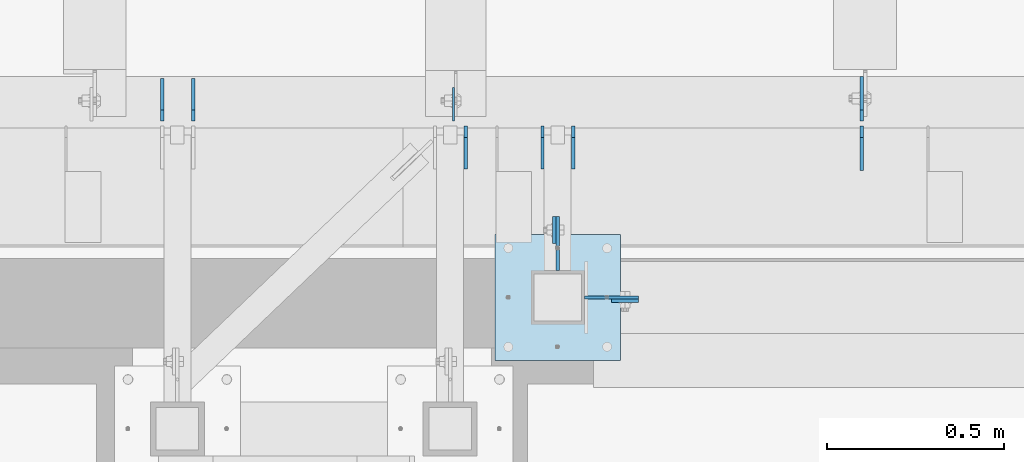
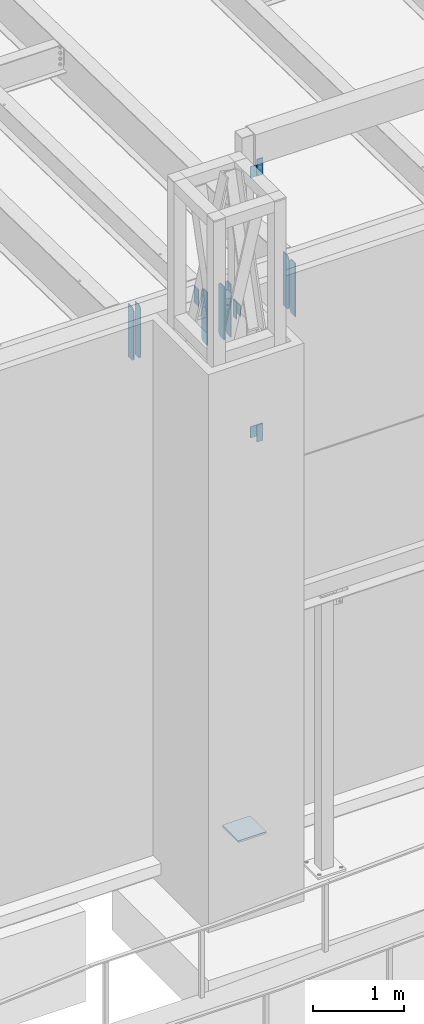
# One storey, part 1430 of 1763: 15 plates, 5 elements without a shape of their own.
"""IFC2X3 building model written with IfcOpenShell, lengths in millimetres."""

import ifcopenshell
import ifcopenshell.guid

model = None  # the IFC model being written
_history = None  # IfcOwnerHistory: only IFC2X3 demands one
_inside = {}  # id of a spatial element -> (the spatial element, [elements in it])
_under = {}  # id of a project, library or spatial element -> (it, [spatial elements below it])
_declared = {}  # id of a project -> (the project, [libraries it declares])
_typed = {}  # id of a type object -> (the type object, [elements of that type])
_made_of = {}  # id of a material, layer set ... -> (it, [elements and type objects made of it])


def new_model(schema):
    """Start an empty IFC model of exactly this schema.

    Asked for "IFC4X3", IfcOpenShell would pick the latest addendum, in which some entities
    have other attributes; the version numbers below select the first issue.
    IFC2X3 requires an IfcOwnerHistory on every rooted entity: one is made here for all.
    """
    global model, _history
    if schema == "IFC4X3":
        model = ifcopenshell.file(schema_version=(4, 3, 0, 0))
    else:
        model = ifcopenshell.file(schema=schema)
    _inside.clear()
    _under.clear()
    _declared.clear()
    _typed.clear()
    _made_of.clear()
    _history = None
    if model.schema == "IFC2X3":
        org = make("IfcOrganization", Name="unknown")
        user = make(
            "IfcPersonAndOrganization",
            ThePerson=make("IfcPerson", FamilyName="unknown"),
            TheOrganization=org,
        )
        app = make(
            "IfcApplication",
            ApplicationDeveloper=org,
            Version="unknown",
            ApplicationFullName="unknown",
            ApplicationIdentifier="unknown",
        )
        _history = make(
            "IfcOwnerHistory",
            OwningUser=user,
            OwningApplication=app,
            ChangeAction="ADDED",
            CreationDate=0,
        )
    return model


def make(cls, **values):
    """One entity of the class cls with the attributes given. An attribute that is None is left unset."""
    return model.create_entity(
        cls, **{name: value for name, value in values.items() if value is not None}
    )


def rooted(cls, **values):
    """An entity with a GlobalId (a new one), such as an element, a storey or a relation."""
    return make(cls, GlobalId=ifcopenshell.guid.new(), OwnerHistory=_history, **values)


def si_unit(unit_type, name, prefix=None):
    """IfcSIUnit, for example si_unit("LENGTHUNIT", "METRE", prefix="MILLI")."""
    return make("IfcSIUnit", UnitType=unit_type, Prefix=prefix, Name=name)


def assignment(units):
    """IfcUnitAssignment: the units of a project."""
    return None if units is None else make("IfcUnitAssignment", Units=units)


def point(xyz):
    """IfcCartesianPoint."""
    return None if xyz is None else make("IfcCartesianPoint", Coordinates=xyz)


def direction(xyz):
    """IfcDirection."""
    return None if xyz is None else make("IfcDirection", DirectionRatios=xyz)


def frame(location, z_axis=None, x_axis=None):
    """IfcAxis2Placement3D, a coordinate frame: its origin and axes. An axis left out is left unset."""
    return make(
        "IfcAxis2Placement3D",
        Location=point(location),
        Axis=direction(z_axis),
        RefDirection=direction(x_axis),
    )


def origin_with_axes():
    """The frame at (0, 0, 0) with the z axis (0, 0, 1) and the x axis (1, 0, 0) written out."""
    return frame((0.0, 0.0, 0.0), z_axis=(0.0, 0.0, 1.0), x_axis=(1.0, 0.0, 0.0))


def place(relative_to, where):
    """IfcLocalPlacement: puts the frame where relative to a parent placement (None: the world)."""
    return make(
        "IfcLocalPlacement", PlacementRelTo=relative_to, RelativePlacement=where
    )


def context(
    kind, dimensions, precision=None, world=None, true_north=None, identifier=None
):
    """IfcGeometricRepresentationContext, for example the 3D "Model" context."""
    return make(
        "IfcGeometricRepresentationContext",
        ContextIdentifier=identifier,
        ContextType=kind,
        CoordinateSpaceDimension=dimensions,
        Precision=precision,
        WorldCoordinateSystem=world,
        TrueNorth=true_north,
    )


def subcontext(parent, identifier, kind, view, scale=None):
    """IfcGeometricRepresentationSubContext, for example "Body" below "Model"."""
    return make(
        "IfcGeometricRepresentationSubContext",
        ContextIdentifier=identifier,
        ContextType=kind,
        ParentContext=parent,
        TargetScale=scale,
        TargetView=view,
    )


def project(units=None, contexts=None):
    """IfcProject with its units and contexts."""
    return rooted(
        "IfcProject",
        Name="project",
        RepresentationContexts=contexts,
        UnitsInContext=assignment(units),
    )


def spatial(cls, under=None, at=None, **own):
    """A site, building, storey or space (cls), placed at a placement, below another one or the project."""
    s = rooted(cls, ObjectPlacement=at, **own)
    if under is not None:
        _under.setdefault(under.id(), (under, []))[1].append(s)
    return s


def faces_of(points, faces, orient=None, outer=None):
    """IfcFace entities. A face is a list of loops; a loop is a list of indices into points, from 0.

    orient and outer hold one flag for each loop. By default every Orientation is true, the
    first loop of a face is its IfcFaceOuterBound and the others are IfcFaceBound.
    """
    made = []
    for i, loops in enumerate(faces):
        bounds = []
        for j, loop in enumerate(loops):
            is_outer = j == 0 if outer is None else outer[i][j]
            bounds.append(
                make(
                    "IfcFaceOuterBound" if is_outer else "IfcFaceBound",
                    Bound=make("IfcPolyLoop", Polygon=[points[k] for k in loop]),
                    Orientation=True if orient is None else orient[i][j],
                )
            )
        made.append(make("IfcFace", Bounds=bounds))
    return made


def faceted_brep(points, faces, orient=None, outer=None, voids=None):
    """IfcFacetedBrep: a solid bounded by flat faces; with voids (closed shells), ...WithVoids."""
    shared = [point(p) for p in points]
    hull = make("IfcClosedShell", CfsFaces=faces_of(shared, faces, orient, outer))
    if voids is None:
        return make("IfcFacetedBrep", Outer=hull)
    return make(
        "IfcFacetedBrepWithVoids",
        Outer=hull,
        Voids=[
            make(cls, CfsFaces=faces_of(shared, fs, o, b)) for cls, fs, o, b in voids
        ],
    )


def shape(context_of_items, identifier, shape_type, items):
    """IfcShapeRepresentation: the items that make up one representation, for example the "Body"."""
    return make(
        "IfcShapeRepresentation",
        ContextOfItems=context_of_items,
        RepresentationIdentifier=identifier,
        RepresentationType=shape_type,
        Items=items,
    )


def material(Name=None, Category=None):
    """IfcMaterial."""
    return make("IfcMaterial", Name=Name, Category=Category)


def made_of(thing, what):
    """Note that an element or type object is made of a material, layer set ...; save() writes the relation."""
    if what is not None:
        _made_of.setdefault(what.id(), (what, []))[1].append(thing)
    return thing


def type_object(cls, material=None, **own):
    """A type object (cls), such as IfcWallType, which elements share."""
    return made_of(rooted(cls, **own), material)


def element(
    cls,
    number,
    at=None,
    inside=None,
    cuts=None,
    type_object=None,
    material=None,
    context=None,
    identifier="Body",
    shape_type=None,
    held_by="IfcProductDefinitionShape",
    body=None,
    shapes=None,
    **own,
):
    """One element of the class cls, such as IfcWall. Its Tag is "e" and its number.

    at: its placement. inside: the storey or other place that contains it. cuts: it is an
    opening in that element (IfcRelVoidsElement). A single representation is given by context,
    identifier, shape_type and body (its items); several are given by shapes. held_by: the class
    of the entity that holds the representations. save() writes the other relations.
    """
    e = rooted(cls, Tag="e%d" % number, ObjectPlacement=at, **own)
    if body is not None:
        shapes = [shape(context, identifier, shape_type, body)]
    if shapes is not None:
        e.Representation = make(held_by, Representations=shapes)
    if inside is not None:
        _inside.setdefault(inside.id(), (inside, []))[1].append(e)
    if cuts is not None:
        rooted(
            "IfcRelVoidsElement", RelatingBuildingElement=cuts, RelatedOpeningElement=e
        )
    if type_object is not None:
        _typed.setdefault(type_object.id(), (type_object, []))[1].append(e)
    return made_of(e, material)


def aggregate(whole, parts):
    """IfcRelAggregates: a whole, such as a stair, and the parts it consists of."""
    return rooted("IfcRelAggregates", RelatingObject=whole, RelatedObjects=parts)


def save(model, path):
    """Write the relations noted so far, then the file.

    IfcRelAggregates (storeys below a building ...), IfcRelContainedInSpatialStructure (elements
    in a storey), IfcRelDefinesByType, IfcRelAssociatesMaterial and IfcRelDeclares: one each for
    every whole, place, type object, material and project.
    """
    for whole, parts in _under.values():
        aggregate(whole, parts)
    for where, things in _inside.values():
        rooted(
            "IfcRelContainedInSpatialStructure",
            RelatedElements=things,
            RelatingStructure=where,
        )
    for kind, things in _typed.values():
        rooted("IfcRelDefinesByType", RelatedObjects=things, RelatingType=kind)
    for what, things in _made_of.values():
        rooted("IfcRelAssociatesMaterial", RelatedObjects=things, RelatingMaterial=what)
    for by, libraries in _declared.values():
        rooted("IfcRelDeclares", RelatingContext=by, RelatedDefinitions=libraries)
    model.write(path)


model = new_model("IFC2X3")

# Units and contexts
model_context = context("Model", 3, precision=1e-05, world=origin_with_axes())
body_context = subcontext(model_context, "Body", "Model", "MODEL_VIEW")
ifc_project = project(units=[si_unit("LENGTHUNIT", "METRE", prefix="MILLI"), si_unit("AREAUNIT", "SQUARE_METRE"), si_unit("VOLUMEUNIT", "CUBIC_METRE"), si_unit("MASSUNIT", "GRAM", prefix="KILO"), si_unit("TIMEUNIT", "SECOND"), si_unit("PLANEANGLEUNIT", "RADIAN"), si_unit("SOLIDANGLEUNIT", "STERADIAN"), si_unit("THERMODYNAMICTEMPERATUREUNIT", "DEGREE_CELSIUS"), si_unit("LUMINOUSINTENSITYUNIT", "LUMEN")], contexts=[model_context])

# Site, building, storey
site_placement = place(None, origin_with_axes())
site = spatial("IfcSite", under=ifc_project, at=site_placement, CompositionType="ELEMENT")
building_placement = place(site_placement, origin_with_axes())
building = spatial("IfcBuilding", under=site, at=building_placement, Name="Undefined", CompositionType="ELEMENT")
storey_placement = place(building_placement, origin_with_axes())
storey = spatial("IfcBuildingStorey", under=building, at=storey_placement, Name="Undefined", CompositionType="ELEMENT", Elevation=0.0)

# Assembly, plate
assembly_1_placement = place(storey_placement, origin_with_axes())
assembly_1 = element("IfcElementAssembly", 1, at=assembly_1_placement, inside=storey, Name="BEAM", AssemblyPlace="NOTDEFINED", PredefinedType="RIGID_FRAME")
ifc_material = material(Name="STEEL/A36")
plate_type_1 = type_object("IfcPlateType", PredefinedType="NOTDEFINED")
plate_1_placement = place(assembly_1_placement, frame((-68849.7577038576, -14217.6514913088, 14058.9), z_axis=(0.0, 0.0, -1.0), x_axis=(1.0, 0.0, 0.0)))
plate_1 = element("IfcPlate", 2, at=plate_1_placement, type_object=plate_type_1, material=ifc_material, Name="PLATE", context=body_context, shape_type="Brep", body=[
    faceted_brep([(0.0, -4.76249999999982, 0.0), (-2.83762346953154e-10, -4.7624999996915, 228.600006103516), (-2.83762346953154e-10, 4.76250000028813, 228.600006103517), (0.0, 4.76249999999982, 0.0), (76.1999969480166, -4.76249999961874, 228.600006103516), (76.1999969480166, 4.76250000036089, 228.600006103517), (76.1999969482931, -4.76249999991705, 0.0), (76.1999969482931, 4.76250000006257, 1.81898940354586e-12)], [[[0, 1, 2, 3]], [[1, 4, 5, 2]], [[4, 6, 7, 5]], [[6, 0, 3, 7]], [[5, 7, 3, 2]], [[6, 4, 1, 0]]]),
])
aggregate(assembly_1, [plate_1])

assembly_2_placement = place(storey_placement, origin_with_axes())
assembly_2 = element("IfcElementAssembly", 3, at=assembly_2_placement, inside=storey, Name="BEAM", AssemblyPlace="NOTDEFINED", PredefinedType="RIGID_FRAME")
plate_2_placement = place(assembly_2_placement, frame((-69011.682522276, -14055.7264648314, 11863.3875), z_axis=(0.0, 0.0, 1.0), x_axis=(0.0, 1.0, 0.0)))
plate_2 = element("IfcPlate", 4, at=plate_2_placement, type_object=plate_type_1, material=ifc_material, Name="PLATE", context=body_context, shape_type="Brep", body=[
    faceted_brep([(0.0, -4.76249999999982, 0.0), (-2.83762346953154e-10, -4.7624999996915, 228.600006103516), (-2.83762346953154e-10, 4.76250000028813, 228.600006103517), (0.0, 4.76249999999982, 0.0), (76.1999969480166, -4.76249999961874, 228.600006103516), (76.1999969480166, 4.76250000036089, 228.600006103517), (76.1999969482931, -4.76249999991705, 0.0), (76.1999969482931, 4.76250000006257, 1.81898940354586e-12)], [[[0, 1, 2, 3]], [[1, 4, 5, 2]], [[4, 6, 7, 5]], [[6, 0, 3, 7]], [[5, 7, 3, 2]], [[6, 4, 1, 0]]]),
])
aggregate(assembly_2, [plate_2])

assembly_3_placement = place(storey_placement, origin_with_axes())
assembly_3 = element("IfcElementAssembly", 5, at=assembly_3_placement, inside=storey, Name="BEAM", AssemblyPlace="NOTDEFINED", PredefinedType="RIGID_FRAME")
plate_3_placement = place(assembly_3_placement, frame((-68849.7577038576, -14217.6514913088, 10248.9), z_axis=(0.0, 0.0, 1.0), x_axis=(1.0, 0.0, 0.0)))
plate_3 = element("IfcPlate", 6, at=plate_3_placement, type_object=plate_type_1, material=ifc_material, Name="PLATE", context=body_context, shape_type="Brep", body=[
    faceted_brep([(0.0, -4.76249999999982, 0.0), (-2.83762346953154e-10, -4.7624999996915, 228.600006103516), (-2.83762346953154e-10, 4.76250000028813, 228.600006103517), (0.0, 4.76249999999982, 0.0), (76.1999969480166, -4.76249999961874, 228.600006103516), (76.1999969480166, 4.76250000036089, 228.600006103517), (76.1999969482931, -4.76249999991705, 0.0), (76.1999969482931, 4.76250000006257, 1.81898940354586e-12)], [[[0, 1, 2, 3]], [[1, 4, 5, 2]], [[4, 6, 7, 5]], [[6, 0, 3, 7]], [[5, 7, 3, 2]], [[6, 4, 1, 0]]]),
])
aggregate(assembly_3, [plate_3])

# Assembly, plates
assembly_4_placement = place(storey_placement, origin_with_axes())
assembly_4 = element("IfcElementAssembly", 7, at=assembly_4_placement, inside=storey, Name="BEAM", AssemblyPlace="NOTDEFINED", PredefinedType="RIGID_FRAME")
plate_type_2 = type_object("IfcPlateType", PredefinedType="NOTDEFINED")
plate_4_placement = place(assembly_4_placement, frame((-69045.0197158888, -13843.7935686171, 11466.5125), z_axis=(0.0, 0.0, 1.0), x_axis=(0.0, 1.0, 0.0)))
plate_4 = element("IfcPlate", 8, at=plate_4_placement, type_object=plate_type_2, material=ifc_material, Name="PLATE", context=body_context, shape_type="Brep", body=[
    faceted_brep([(0.0, -4.76249999999982, 0.0), (0.0, -4.76249999999709, 717.549987792969), (0.0, 4.76249999999709, 717.549987792969), (0.0, 4.76249999999982, 0.0), (88.9000015258789, -4.76249999999709, 717.549987792969), (88.9000015258789, 4.76249999999709, 717.549987792969), (120.650001525879, -4.76249999999709, 685.799987792969), (120.650001525879, 4.76249999999709, 685.799987792969), (120.650001525879, -4.76249999999709, 31.75), (120.650001525879, 4.76249999999709, 31.75), (88.9000015258789, -4.76249999999709, 0.0), (88.9000015258789, 4.76249999999709, 0.0)], [[[0, 1, 2, 3]], [[1, 4, 5, 2]], [[4, 6, 7, 5]], [[6, 8, 9, 7]], [[8, 10, 11, 9]], [[10, 0, 3, 11]], [[5, 7, 9, 11, 3, 2]], [[10, 8, 6, 4, 1, 0]]]),
])
plate_5_placement = place(assembly_4_placement, frame((-68957.7082158888, -13843.7935686171, 11466.5125), z_axis=(0.0, 0.0, 1.0), x_axis=(0.0, 1.0, 0.0)))
plate_5 = element("IfcPlate", 9, at=plate_5_placement, type_object=plate_type_2, material=ifc_material, Name="PLATE", context=body_context, shape_type="Brep", body=[
    faceted_brep([(0.0, -4.76249999999982, 0.0), (0.0, -4.76249999999709, 717.549987792969), (0.0, 4.76249999999709, 717.549987792969), (0.0, 4.76249999999982, 0.0), (88.9000015258789, -4.76249999999709, 717.549987792969), (88.9000015258789, 4.76249999999709, 717.549987792969), (120.650001525879, -4.76249999999709, 685.799987792969), (120.650001525879, 4.76249999999709, 685.799987792969), (120.650001525879, -4.76249999999709, 31.75), (120.650001525879, 4.76249999999709, 31.75), (88.9000015258789, -4.76249999999709, 0.0), (88.9000015258789, 4.76249999999709, 0.0)], [[[0, 1, 2, 3]], [[1, 4, 5, 2]], [[4, 6, 7, 5]], [[6, 8, 9, 7]], [[8, 10, 11, 9]], [[10, 0, 3, 11]], [[5, 7, 9, 11, 3, 2]], [[10, 8, 6, 4, 1, 0]]]),
])
plate_6_placement = place(assembly_4_placement, frame((-69262.06238459, -13843.7935686171, 11466.5125), z_axis=(0.0, 0.0, 1.0), x_axis=(0.0, 1.0, 0.0)))
plate_6 = element("IfcPlate", 10, at=plate_6_placement, type_object=plate_type_2, material=ifc_material, Name="PLATE", context=body_context, shape_type="Brep", body=[
    faceted_brep([(0.0, -4.76249999999982, 0.0), (0.0, -4.76249999999709, 717.549987792969), (0.0, 4.76249999999709, 717.549987792969), (0.0, 4.76249999999982, 0.0), (88.9000015258789, -4.76249999999709, 717.549987792969), (88.9000015258789, 4.76249999999709, 717.549987792969), (120.650001525879, -4.76249999999709, 685.799987792969), (120.650001525879, 4.76249999999709, 685.799987792969), (120.650001525879, -4.76249999999709, 31.75), (120.650001525879, 4.76249999999709, 31.75), (88.9000015258789, -4.76249999999709, 0.0), (88.9000015258789, 4.76249999999709, 0.0)], [[[0, 1, 2, 3]], [[1, 4, 5, 2]], [[4, 6, 7, 5]], [[6, 8, 9, 7]], [[8, 10, 11, 9]], [[10, 0, 3, 11]], [[5, 7, 9, 11, 3, 2]], [[10, 8, 6, 4, 1, 0]]]),
])
plate_7_placement = place(assembly_4_placement, frame((-70033.58738459, -13708.8560686171, 11466.5125), z_axis=(0.0, 0.0, 1.0), x_axis=(0.0, 1.0, 0.0)))
plate_7 = element("IfcPlate", 11, at=plate_7_placement, type_object=plate_type_2, material=ifc_material, Name="PLATE", context=body_context, shape_type="Brep", body=[
    faceted_brep([(0.0, -4.76250000000073, 31.75), (0.0, -4.76250000000073, 685.799987792969), (0.0, 4.76250000000073, 685.799987792969), (0.0, 4.76250000000073, 31.75), (31.75, -4.76250000000073, 717.549987792969), (31.75, 4.76250000000073, 717.549987792969), (120.650001525879, -4.76249999999709, 717.549987792969), (120.650001525879, 4.76249999999709, 717.549987792969), (120.650001525879, -4.76249999999709, 0.0), (120.650001525879, 4.76249999999709, 0.0), (31.75, -4.76250000000073, 0.0), (31.75, 4.76250000000073, 0.0)], [[[0, 1, 2, 3]], [[1, 4, 5, 2]], [[4, 6, 7, 5]], [[6, 8, 9, 7]], [[8, 10, 11, 9]], [[10, 0, 3, 11]], [[5, 7, 9, 11, 3, 2]], [[10, 8, 6, 4, 1, 0]]]),
])
plate_8_placement = place(assembly_4_placement, frame((-70120.89938459, -13708.8560686171, 11466.5125), z_axis=(0.0, 0.0, 1.0), x_axis=(0.0, 1.0, 0.0)))
plate_8 = element("IfcPlate", 12, at=plate_8_placement, type_object=plate_type_2, material=ifc_material, Name="PLATE", context=body_context, shape_type="Brep", body=[
    faceted_brep([(0.0, -4.76250000000073, 31.75), (0.0, -4.76250000000073, 685.799987792969), (0.0, 4.76250000000073, 685.799987792969), (0.0, 4.76250000000073, 31.75), (31.75, -4.76250000000073, 717.549987792969), (31.75, 4.76250000000073, 717.549987792969), (120.650001525879, -4.76249999999709, 717.549987792969), (120.650001525879, 4.76249999999709, 717.549987792969), (120.650001525879, -4.76249999999709, 0.0), (120.650001525879, 4.76249999999709, 0.0), (31.75, -4.76250000000073, 0.0), (31.75, 4.76250000000073, 0.0)], [[[0, 1, 2, 3]], [[1, 4, 5, 2]], [[4, 6, 7, 5]], [[6, 8, 9, 7]], [[8, 10, 11, 9]], [[10, 0, 3, 11]], [[5, 7, 9, 11, 3, 2]], [[10, 8, 6, 4, 1, 0]]]),
])

assembly_5_placement = place(storey_placement, origin_with_axes())
assembly_5 = element("IfcElementAssembly", 13, at=assembly_5_placement, inside=storey, Name="COLUMN", AssemblyPlace="NOTDEFINED", PredefinedType="RIGID_FRAME")
plate_type_3 = type_object("IfcPlateType", PredefinedType="NOTDEFINED")
plate_9_placement = place(assembly_5_placement, frame((-68773.5577069569, -14208.126492046, 13830.2999938965), z_axis=(0.0, 0.0, 1.0), x_axis=(-1.0, 0.0, 0.0)))
plate_9 = element("IfcPlate", 14, at=plate_9_placement, type_object=plate_type_3, material=ifc_material, Name="PLATE", context=body_context, shape_type="Brep", body=[
    faceted_brep([(0.0, -4.76249999999982, 0.0), (-3.05175672110636e-06, -4.7625000002663, 152.399993896484), (-3.05175490211695e-06, 4.76249999972788, 152.399993896484), (0.0, 4.76249999999982, 0.0), (152.400009155272, -4.76249999975698, 152.399993896484), (152.400009155273, 4.76250000024447, 152.399993896484), (152.400009155272, -4.76249999948777, 5.45696821063757e-12), (152.400009155273, 4.76250000051368, 3.63797880709171e-12)], [[[0, 1, 2, 3]], [[1, 4, 5, 2]], [[4, 6, 7, 5]], [[6, 0, 3, 7]], [[5, 7, 3, 2]], [[6, 4, 1, 0]]]),
])
plate_10_placement = place(assembly_5_placement, frame((-69002.157523776, -13979.5264678355, 12091.9875061035), z_axis=(0.0, 0.0, -1.0), x_axis=(0.0, -1.0, 0.0)))
plate_10 = element("IfcPlate", 15, at=plate_10_placement, type_object=plate_type_3, material=ifc_material, Name="PLATE", context=body_context, shape_type="Brep", body=[
    faceted_brep([(0.0, -4.76249999999982, 0.0), (-3.05175672110636e-06, -4.7625000002663, 152.399993896484), (-3.05175490211695e-06, 4.76249999972788, 152.399993896484), (0.0, 4.76249999999982, 0.0), (152.400009155272, -4.76249999975698, 152.399993896484), (152.400009155273, 4.76250000024447, 152.399993896484), (152.400009155272, -4.76249999948777, 5.45696821063757e-12), (152.400009155273, 4.76250000051368, 3.63797880709171e-12)], [[[0, 1, 2, 3]], [[1, 4, 5, 2]], [[4, 6, 7, 5]], [[6, 0, 3, 7]], [[5, 7, 3, 2]], [[6, 4, 1, 0]]]),
])
plate_11_placement = place(assembly_5_placement, frame((-68773.5577069569, -14208.126492046, 10477.5000061035), z_axis=(0.0, 0.0, -1.0), x_axis=(-1.0, 0.0, 0.0)))
plate_11 = element("IfcPlate", 16, at=plate_11_placement, type_object=plate_type_3, material=ifc_material, Name="PLATE", context=body_context, shape_type="Brep", body=[
    faceted_brep([(0.0, -4.76249999999982, 0.0), (-3.05175672110636e-06, -4.7625000002663, 152.399993896484), (-3.05175490211695e-06, 4.76249999972788, 152.399993896484), (0.0, 4.76249999999982, 0.0), (152.400009155272, -4.76249999975698, 152.399993896484), (152.400009155273, 4.76250000024447, 152.399993896484), (152.400009155272, -4.76249999948777, 5.45696821063757e-12), (152.400009155273, 4.76250000051368, 3.63797880709171e-12)], [[[0, 1, 2, 3]], [[1, 4, 5, 2]], [[4, 6, 7, 5]], [[6, 0, 3, 7]], [[5, 7, 3, 2]], [[6, 4, 1, 0]]]),
])

# Plate
plate_type_4 = type_object("IfcPlateType", PredefinedType="NOTDEFINED")
plate_12_placement = place(assembly_4_placement, frame((-69296.9868842947, -13708.8560686171, 12154.1242965529), z_axis=(0.0, 1.0, 0.0), x_axis=(0.0, 0.0, -1.0)))
plate_12 = element("IfcPlate", 17, at=plate_12_placement, type_object=plate_type_4, material=ifc_material, Name="PLATE", context=body_context, shape_type="Brep", body=[
    faceted_brep([(1.81898940354586e-12, -3.17500000000291, 0.0), (0.0, -3.17499999999927, 95.25), (0.0, 3.17499999999927, 95.25), (-1.81898940354586e-12, 3.17499999997381, 0.0), (228.600006103516, -3.17500000000291, 95.25), (228.600006103516, 3.17500000000291, 95.25), (228.600006103516, -3.17500000001019, -7.27595761418343e-12), (228.600006103516, 3.17499999999563, -7.27595761418343e-12)], [[[0, 1, 2, 3]], [[1, 4, 5, 2]], [[4, 6, 7, 5]], [[6, 0, 3, 7]], [[5, 7, 3, 2]], [[6, 4, 1, 0]]]),
])

plate_type_5 = type_object("IfcPlateType", PredefinedType="NOTDEFINED")
plate_13_placement = place(assembly_5_placement, frame((-69179.9577158888, -14030.3264769908, 5080.0), z_axis=(1.0, 0.0, 0.0), x_axis=(0.0, -1.0, 0.0)))
plate_13 = element("IfcPlate", 18, at=plate_13_placement, type_object=plate_type_5, material=ifc_material, Name="PLATE", context=body_context, shape_type="Brep", body=[
    faceted_brep([(0.0, -12.6999999999971, -1.81898940354586e-12), (0.0, -12.6999999999998, 355.600006103516), (0.0, 12.6999999999998, 355.600006103516), (0.0, 12.6999999999971, -1.81898940354586e-12), (355.600006103516, -12.6999999999998, 355.600006103516), (355.600006103516, 12.6999999999998, 355.600006103516), (355.600006103516, -12.6999999999998, 0.0), (355.600006103516, 12.6999999999998, 0.0)], [[[0, 1, 2, 3]], [[1, 4, 5, 2]], [[4, 6, 7, 5]], [[6, 0, 3, 7]], [[5, 7, 3, 2]], [[6, 4, 1, 0]]]),
])

aggregate(assembly_5, [plate_13, plate_9, plate_10, plate_11])

plate_type_6 = type_object("IfcPlateType", PredefinedType="NOTDEFINED")
plate_14_placement = place(assembly_4_placement, frame((-68141.9227736144, -13723.1435686171, 11464.925), z_axis=(0.0, 0.0, 1.0), x_axis=(0.0, -1.0, 0.0)))
plate_14 = element("IfcPlate", 19, at=plate_14_placement, type_object=plate_type_6, material=ifc_material, Name="PLATE", context=body_context, shape_type="Brep", body=[
    faceted_brep([(0.0, -4.76250000000073, 31.75), (0.0, -4.76249999999709, 688.974975585938), (0.0, 4.76249999999709, 688.974975585938), (0.0, 4.76250000000073, 31.75), (31.75, -4.76249999999709, 720.724975585938), (31.75, 4.76249999999709, 720.724975585938), (126.206253051758, -4.76249999999709, 720.724975585938), (126.206253051758, 4.76249999999709, 720.724975585938), (126.206253051758, -4.76249999999709, 0.0), (126.206253051758, 4.76249999999709, 0.0), (31.75, -4.76250000000073, 0.0), (31.75, 4.76250000000073, 0.0)], [[[0, 1, 2, 3]], [[1, 4, 5, 2]], [[4, 6, 7, 5]], [[6, 8, 9, 7]], [[8, 10, 11, 9]], [[10, 0, 3, 11]], [[5, 7, 9, 11, 3, 2]], [[10, 8, 6, 4, 1, 0]]]),
])

plate_type_7 = type_object("IfcPlateType", PredefinedType="NOTDEFINED")
plate_15_placement = place(assembly_4_placement, frame((-68141.9227736144, -13708.8560686171, 11466.5125), z_axis=(0.0, 0.0, 1.0), x_axis=(0.0, 1.0, 0.0)))
plate_15 = element("IfcPlate", 20, at=plate_15_placement, type_object=plate_type_7, material=ifc_material, Name="PLATE", context=body_context, shape_type="Brep", body=[
    faceted_brep([(0.0, -4.76250000000073, 31.75), (0.0, -4.76249999999709, 687.387512207031), (0.0, 4.76249999999709, 687.387512207031), (0.0, 4.76250000000073, 31.75), (31.75, -4.76249999999709, 719.137512207031), (31.75, 4.76249999999709, 719.137512207031), (125.412498474121, -4.76249999999709, 719.137512207031), (125.412498474121, 4.76249999999709, 719.137512207031), (125.412498474121, -4.76249999999709, 0.0), (125.412498474121, 4.76249999999709, 0.0), (31.75, -4.76250000000073, 0.0), (31.75, 4.76250000000073, 0.0)], [[[0, 1, 2, 3]], [[1, 4, 5, 2]], [[4, 6, 7, 5]], [[6, 8, 9, 7]], [[8, 10, 11, 9]], [[10, 0, 3, 11]], [[5, 7, 9, 11, 3, 2]], [[10, 8, 6, 4, 1, 0]]]),
])

aggregate(assembly_4, [plate_4, plate_5, plate_6, plate_7, plate_8, plate_14, plate_15, plate_12])

save(model, "model.ifc")
